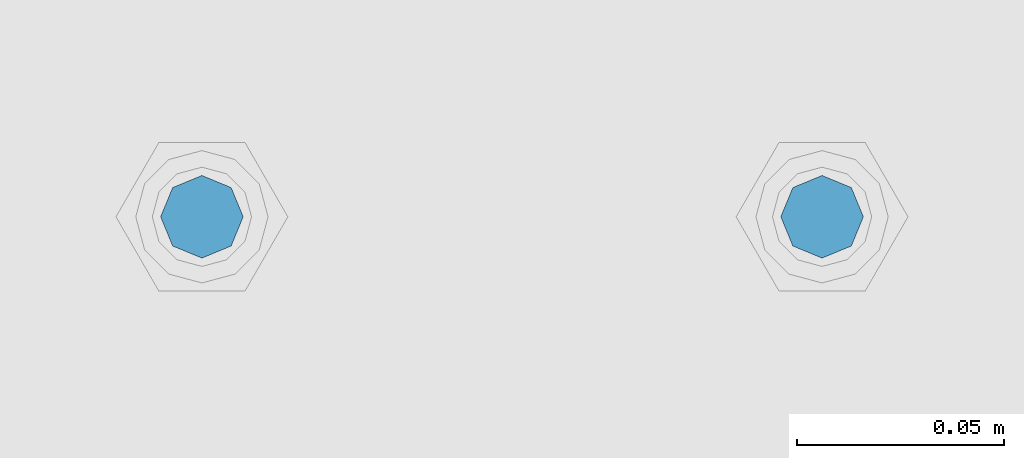
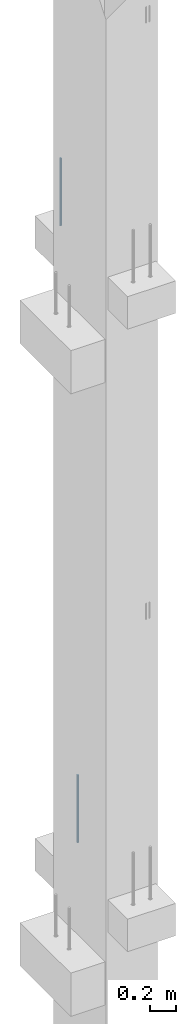
# One storey, part 16 of 41: 2 beams, 1 element without a shape of its own.
"""IFC2X3 building model written with IfcOpenShell, lengths in millimetres."""

from ifc_helpers import new_model, si_unit, frame, origin_with_axes, place, context, subcontext, project, spatial, faceted_brep, material, type_object, element, aggregate, save


model = new_model("IFC2X3")

# Units and contexts
model_context = context("Model", 3, precision=1e-05, world=origin_with_axes())
body_context = subcontext(model_context, "Body", "Model", "MODEL_VIEW")
ifc_project = project(units=[si_unit("LENGTHUNIT", "METRE", prefix="MILLI"), si_unit("AREAUNIT", "SQUARE_METRE"), si_unit("VOLUMEUNIT", "CUBIC_METRE"), si_unit("MASSUNIT", "GRAM", prefix="KILO"), si_unit("TIMEUNIT", "SECOND"), si_unit("PLANEANGLEUNIT", "RADIAN"), si_unit("SOLIDANGLEUNIT", "STERADIAN"), si_unit("THERMODYNAMICTEMPERATUREUNIT", "DEGREE_CELSIUS"), si_unit("LUMINOUSINTENSITYUNIT", "LUMEN")], contexts=[model_context])

# Site, building, storey
site_placement = place(None, frame((-177556.685383467, -198018.589999756, 1290.0), z_axis=(0.0, 0.0, 1.0), x_axis=(0.788225611989142, -0.615386370180835, 0.0)))
site = spatial("IfcSite", under=ifc_project, at=site_placement, CompositionType="ELEMENT")
building_placement = place(site_placement, origin_with_axes())
building = spatial("IfcBuilding", under=site, at=building_placement, Name="Undefined", CompositionType="ELEMENT")
storey_placement = place(building_placement, origin_with_axes())
storey = spatial("IfcBuildingStorey", under=building, at=storey_placement, Name="Undefined", CompositionType="ELEMENT", Elevation=0.0)

# Assembly, beams
assembly_placement = place(storey_placement, origin_with_axes())
assembly = element("IfcElementAssembly", 1, at=assembly_placement, inside=storey, AssemblyPlace="NOTDEFINED", PredefinedType="REINFORCEMENT_UNIT")
ifc_material = material(Name="STEEL/S235JR")
beam_type = type_object("IfcBeamType", PredefinedType="NOTDEFINED")
beam_1_placement = place(assembly_placement, frame((17817.4400881731, 265828.966471616, 6230.0), z_axis=(-0.615386219627735, 0.788225729529483, 0.0), x_axis=(0.0, 0.0, -1.0)))
beam_1 = element("IfcBeam", 2, at=beam_1_placement, type_object=beam_type, material=ifc_material, context=body_context, shape_type="Brep", body=[
    faceted_brep([(4.88085788674653e-07, -10.0, -3.86498868465424e-08), (0.0, -7.07106819456385, -7.07106766643119), (624.0, -7.0710680251359, -7.07106751203537), (624.0, -10.0000002132438, 2.99856765195727e-07), (4.97872867461239e-11, -3.88578058618805e-15, -10.0), (624.0, -2.13272869586945e-07, -9.99999970020144), (0.0, 7.07106742914766, -7.0710676664894), (624.0, 7.07106759861927, -7.07106751209358), (4.88085788674653e-07, 10.0, -3.86498868465424e-08), (624.0, 9.99999978675623, 2.99711246043444e-07), (0.0, 7.07106742919132, 7.07106795720756), (624.0, 7.07106759864837, 7.07106811160338), (-4.97872867461239e-11, 0.0, 10.0), (624.0, -2.13214661926031e-07, 10.0000002997695), (0.0, -7.07106819453475, 7.07106795729487), (624.0, -7.0710680251068, 7.07106811166159)], [[[0, 1, 2, 3]], [[1, 4, 5, 2]], [[4, 6, 7, 5]], [[6, 8, 9, 7]], [[8, 10, 11, 9]], [[10, 12, 13, 11]], [[12, 14, 15, 13]], [[14, 0, 3, 15]], [[5, 7, 9, 11, 13, 15, 3, 2]], [[14, 12, 10, 8, 6, 4, 1, 0]]]),
])
beam_2_placement = place(assembly_placement, frame((17699.206246375, 265736.658516089, 11990.0), z_axis=(-0.615386219627735, 0.788225729529483, 0.0), x_axis=(0.0, 0.0, -1.0)))
beam_2 = element("IfcBeam", 3, at=beam_2_placement, type_object=beam_type, material=ifc_material, context=body_context, shape_type="Brep", body=[
    faceted_brep([(4.88085788674653e-07, -10.0, -3.86498868465424e-08), (0.0, -7.07106819456385, -7.07106766643119), (624.0, -7.0710680251359, -7.07106751203537), (624.0, -10.0000002132438, 2.99856765195727e-07), (4.97872867461239e-11, -3.88578058618805e-15, -10.0), (624.0, -2.13272869586945e-07, -9.99999970020144), (0.0, 7.07106742914766, -7.0710676664894), (624.0, 7.07106759861927, -7.07106751209358), (4.88085788674653e-07, 10.0, -3.86498868465424e-08), (624.0, 9.99999978675623, 2.99711246043444e-07), (0.0, 7.07106742919132, 7.07106795720756), (624.0, 7.07106759864837, 7.07106811160338), (-4.97872867461239e-11, 0.0, 10.0), (624.0, -2.13214661926031e-07, 10.0000002997695), (0.0, -7.07106819453475, 7.07106795729487), (624.0, -7.0710680251068, 7.07106811166159)], [[[0, 1, 2, 3]], [[1, 4, 5, 2]], [[4, 6, 7, 5]], [[6, 8, 9, 7]], [[8, 10, 11, 9]], [[10, 12, 13, 11]], [[12, 14, 15, 13]], [[14, 0, 3, 15]], [[5, 7, 9, 11, 13, 15, 3, 2]], [[14, 12, 10, 8, 6, 4, 1, 0]]]),
])
aggregate(assembly, [beam_1, beam_2])

save(model, "model.ifc")
